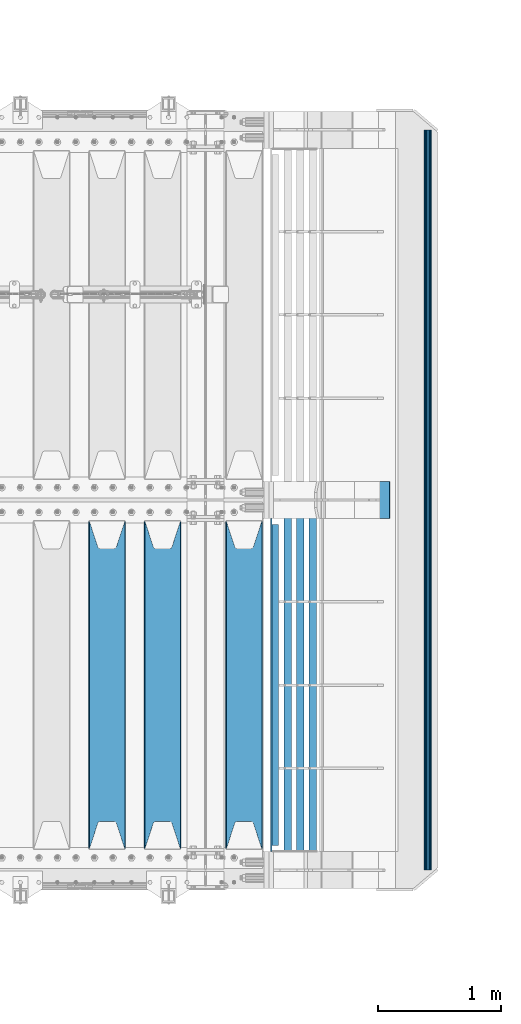
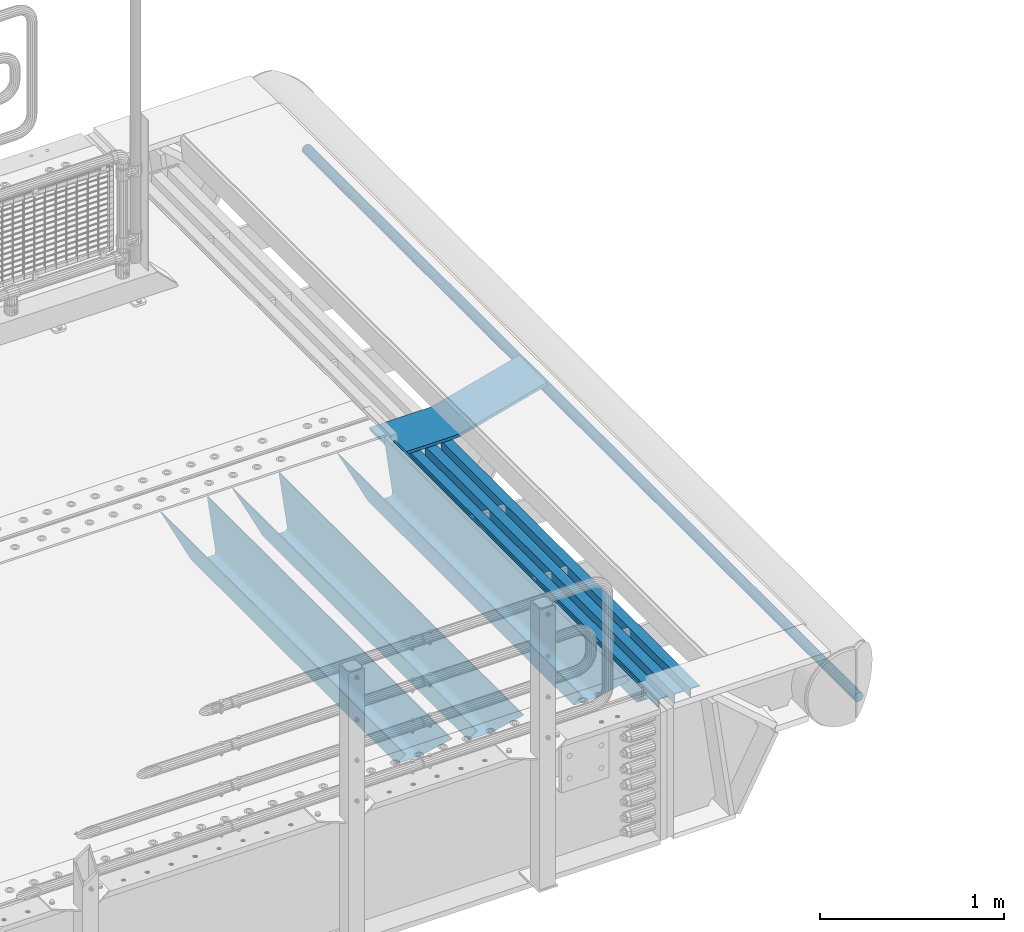
# One storey, part 131 of 242: 9 beams.
"""IFC2X3 building model written with IfcOpenShell, lengths in millimetres."""

import ifcopenshell
import ifcopenshell.guid

model = None  # the IFC model being written
_history = None  # IfcOwnerHistory: only IFC2X3 demands one
_inside = {}  # id of a spatial element -> (the spatial element, [elements in it])
_under = {}  # id of a project, library or spatial element -> (it, [spatial elements below it])
_declared = {}  # id of a project -> (the project, [libraries it declares])
_typed = {}  # id of a type object -> (the type object, [elements of that type])
_made_of = {}  # id of a material, layer set ... -> (it, [elements and type objects made of it])


def new_model(schema):
    """Start an empty IFC model of exactly this schema.

    Asked for "IFC4X3", IfcOpenShell would pick the latest addendum, in which some entities
    have other attributes; the version numbers below select the first issue.
    IFC2X3 requires an IfcOwnerHistory on every rooted entity: one is made here for all.
    """
    global model, _history
    if schema == "IFC4X3":
        model = ifcopenshell.file(schema_version=(4, 3, 0, 0))
    else:
        model = ifcopenshell.file(schema=schema)
    _inside.clear()
    _under.clear()
    _declared.clear()
    _typed.clear()
    _made_of.clear()
    _history = None
    if model.schema == "IFC2X3":
        org = make("IfcOrganization", Name="unknown")
        user = make(
            "IfcPersonAndOrganization",
            ThePerson=make("IfcPerson", FamilyName="unknown"),
            TheOrganization=org,
        )
        app = make(
            "IfcApplication",
            ApplicationDeveloper=org,
            Version="unknown",
            ApplicationFullName="unknown",
            ApplicationIdentifier="unknown",
        )
        _history = make(
            "IfcOwnerHistory",
            OwningUser=user,
            OwningApplication=app,
            ChangeAction="ADDED",
            CreationDate=0,
        )
    return model


def make(cls, **values):
    """One entity of the class cls with the attributes given. An attribute that is None is left unset."""
    return model.create_entity(
        cls, **{name: value for name, value in values.items() if value is not None}
    )


def rooted(cls, **values):
    """An entity with a GlobalId (a new one), such as an element, a storey or a relation."""
    return make(cls, GlobalId=ifcopenshell.guid.new(), OwnerHistory=_history, **values)


def si_unit(unit_type, name, prefix=None):
    """IfcSIUnit, for example si_unit("LENGTHUNIT", "METRE", prefix="MILLI")."""
    return make("IfcSIUnit", UnitType=unit_type, Prefix=prefix, Name=name)


def assignment(units):
    """IfcUnitAssignment: the units of a project."""
    return None if units is None else make("IfcUnitAssignment", Units=units)


def point(xyz):
    """IfcCartesianPoint."""
    return None if xyz is None else make("IfcCartesianPoint", Coordinates=xyz)


def direction(xyz):
    """IfcDirection."""
    return None if xyz is None else make("IfcDirection", DirectionRatios=xyz)


def frame(location, z_axis=None, x_axis=None):
    """IfcAxis2Placement3D, a coordinate frame: its origin and axes. An axis left out is left unset."""
    return make(
        "IfcAxis2Placement3D",
        Location=point(location),
        Axis=direction(z_axis),
        RefDirection=direction(x_axis),
    )


def origin_with_axes():
    """The frame at (0, 0, 0) with the z axis (0, 0, 1) and the x axis (1, 0, 0) written out."""
    return frame((0.0, 0.0, 0.0), z_axis=(0.0, 0.0, 1.0), x_axis=(1.0, 0.0, 0.0))


def place(relative_to, where):
    """IfcLocalPlacement: puts the frame where relative to a parent placement (None: the world)."""
    return make(
        "IfcLocalPlacement", PlacementRelTo=relative_to, RelativePlacement=where
    )


def context(
    kind, dimensions, precision=None, world=None, true_north=None, identifier=None
):
    """IfcGeometricRepresentationContext, for example the 3D "Model" context."""
    return make(
        "IfcGeometricRepresentationContext",
        ContextIdentifier=identifier,
        ContextType=kind,
        CoordinateSpaceDimension=dimensions,
        Precision=precision,
        WorldCoordinateSystem=world,
        TrueNorth=true_north,
    )


def subcontext(parent, identifier, kind, view, scale=None):
    """IfcGeometricRepresentationSubContext, for example "Body" below "Model"."""
    return make(
        "IfcGeometricRepresentationSubContext",
        ContextIdentifier=identifier,
        ContextType=kind,
        ParentContext=parent,
        TargetScale=scale,
        TargetView=view,
    )


def project(units=None, contexts=None):
    """IfcProject with its units and contexts."""
    return rooted(
        "IfcProject",
        Name="project",
        RepresentationContexts=contexts,
        UnitsInContext=assignment(units),
    )


def spatial(cls, under=None, at=None, **own):
    """A site, building, storey or space (cls), placed at a placement, below another one or the project."""
    s = rooted(cls, ObjectPlacement=at, **own)
    if under is not None:
        _under.setdefault(under.id(), (under, []))[1].append(s)
    return s


def faces_of(points, faces, orient=None, outer=None):
    """IfcFace entities. A face is a list of loops; a loop is a list of indices into points, from 0.

    orient and outer hold one flag for each loop. By default every Orientation is true, the
    first loop of a face is its IfcFaceOuterBound and the others are IfcFaceBound.
    """
    made = []
    for i, loops in enumerate(faces):
        bounds = []
        for j, loop in enumerate(loops):
            is_outer = j == 0 if outer is None else outer[i][j]
            bounds.append(
                make(
                    "IfcFaceOuterBound" if is_outer else "IfcFaceBound",
                    Bound=make("IfcPolyLoop", Polygon=[points[k] for k in loop]),
                    Orientation=True if orient is None else orient[i][j],
                )
            )
        made.append(make("IfcFace", Bounds=bounds))
    return made


def faceted_brep(points, faces, orient=None, outer=None, voids=None):
    """IfcFacetedBrep: a solid bounded by flat faces; with voids (closed shells), ...WithVoids."""
    shared = [point(p) for p in points]
    hull = make("IfcClosedShell", CfsFaces=faces_of(shared, faces, orient, outer))
    if voids is None:
        return make("IfcFacetedBrep", Outer=hull)
    return make(
        "IfcFacetedBrepWithVoids",
        Outer=hull,
        Voids=[
            make(cls, CfsFaces=faces_of(shared, fs, o, b)) for cls, fs, o, b in voids
        ],
    )


def shape(context_of_items, identifier, shape_type, items):
    """IfcShapeRepresentation: the items that make up one representation, for example the "Body"."""
    return make(
        "IfcShapeRepresentation",
        ContextOfItems=context_of_items,
        RepresentationIdentifier=identifier,
        RepresentationType=shape_type,
        Items=items,
    )


def material(Name=None, Category=None):
    """IfcMaterial."""
    return make("IfcMaterial", Name=Name, Category=Category)


def made_of(thing, what):
    """Note that an element or type object is made of a material, layer set ...; save() writes the relation."""
    if what is not None:
        _made_of.setdefault(what.id(), (what, []))[1].append(thing)
    return thing


def type_object(cls, material=None, **own):
    """A type object (cls), such as IfcWallType, which elements share."""
    return made_of(rooted(cls, **own), material)


def element(
    cls,
    number,
    at=None,
    inside=None,
    cuts=None,
    type_object=None,
    material=None,
    context=None,
    identifier="Body",
    shape_type=None,
    held_by="IfcProductDefinitionShape",
    body=None,
    shapes=None,
    **own,
):
    """One element of the class cls, such as IfcWall. Its Tag is "e" and its number.

    at: its placement. inside: the storey or other place that contains it. cuts: it is an
    opening in that element (IfcRelVoidsElement). A single representation is given by context,
    identifier, shape_type and body (its items); several are given by shapes. held_by: the class
    of the entity that holds the representations. save() writes the other relations.
    """
    e = rooted(cls, Tag="e%d" % number, ObjectPlacement=at, **own)
    if body is not None:
        shapes = [shape(context, identifier, shape_type, body)]
    if shapes is not None:
        e.Representation = make(held_by, Representations=shapes)
    if inside is not None:
        _inside.setdefault(inside.id(), (inside, []))[1].append(e)
    if cuts is not None:
        rooted(
            "IfcRelVoidsElement", RelatingBuildingElement=cuts, RelatedOpeningElement=e
        )
    if type_object is not None:
        _typed.setdefault(type_object.id(), (type_object, []))[1].append(e)
    return made_of(e, material)


def aggregate(whole, parts):
    """IfcRelAggregates: a whole, such as a stair, and the parts it consists of."""
    return rooted("IfcRelAggregates", RelatingObject=whole, RelatedObjects=parts)


def save(model, path):
    """Write the relations noted so far, then the file.

    IfcRelAggregates (storeys below a building ...), IfcRelContainedInSpatialStructure (elements
    in a storey), IfcRelDefinesByType, IfcRelAssociatesMaterial and IfcRelDeclares: one each for
    every whole, place, type object, material and project.
    """
    for whole, parts in _under.values():
        aggregate(whole, parts)
    for where, things in _inside.values():
        rooted(
            "IfcRelContainedInSpatialStructure",
            RelatedElements=things,
            RelatingStructure=where,
        )
    for kind, things in _typed.values():
        rooted("IfcRelDefinesByType", RelatedObjects=things, RelatingType=kind)
    for what, things in _made_of.values():
        rooted("IfcRelAssociatesMaterial", RelatedObjects=things, RelatingMaterial=what)
    for by, libraries in _declared.values():
        rooted("IfcRelDeclares", RelatingContext=by, RelatedDefinitions=libraries)
    model.write(path)


model = new_model("IFC2X3")

# Units and contexts
model_context = context("Model", 3, precision=1e-05, world=origin_with_axes())
body_context = subcontext(model_context, "Body", "Model", "MODEL_VIEW")
ifc_project = project(units=[si_unit("LENGTHUNIT", "METRE", prefix="MILLI"), si_unit("AREAUNIT", "SQUARE_METRE"), si_unit("VOLUMEUNIT", "CUBIC_METRE"), si_unit("MASSUNIT", "GRAM", prefix="KILO"), si_unit("TIMEUNIT", "SECOND"), si_unit("PLANEANGLEUNIT", "RADIAN"), si_unit("SOLIDANGLEUNIT", "STERADIAN"), si_unit("THERMODYNAMICTEMPERATUREUNIT", "DEGREE_CELSIUS"), si_unit("LUMINOUSINTENSITYUNIT", "LUMEN")], contexts=[model_context])

# Site, building, storey
site_placement = place(None, origin_with_axes())
site = spatial("IfcSite", under=ifc_project, at=site_placement, CompositionType="ELEMENT")
building_placement = place(site_placement, origin_with_axes())
building = spatial("IfcBuilding", under=site, at=building_placement, Name="Standard", CompositionType="ELEMENT")
storey_placement = place(building_placement, origin_with_axes())
storey = spatial("IfcBuildingStorey", under=building, at=storey_placement, Name="Undefined", CompositionType="ELEMENT", Elevation=0.0)

# Beams
ifc_material_1 = material(Name="STEEL/S355N")
beam_type_1 = type_object("IfcBeamType", PredefinedType="NOTDEFINED")
beam_1_placement = place(storey_placement, frame((-22220.0, -23825.0, -115.0), z_axis=(0.0, 0.0, 1.0), x_axis=(0.0, 1.0, 0.0)))
element("IfcBeam", 1, at=beam_1_placement, inside=storey, type_object=beam_type_1, material=ifc_material_1, context=body_context, shape_type="Brep", body=[
    faceted_brep([(0.0, 150.0, 115.0), (0.0, 143.689999999999, 115.0), (2650.00000000297, 143.689999999999, 115.0), (2650.00000000297, 150.0, 115.0), (2650.00000000297, 142.059565218402, 110.000000003099), (2650.00000000297, 148.369565218403, 110.000000003099), (2441.90079219209, -80.1103600731112, -98.0992078077845), (2437.7588105432, -77.5672621345584, -102.241189456673), (2434.06523489747, -74.4080125315522, -105.934765102404), (2430.91086095089, -70.710272125576, -109.089139048974), (2428.37322971128, -66.5649389910068, -111.626770288588), (2426.51472138055, -62.0739139532889, -113.485278619323), (2425.38102192092, -57.3475956567672, -114.618978078955), (2424.99999999987, -52.5021667386536, -115.0), (2424.99999999987, 52.5021667386536, -115.0), (2425.38102192092, 57.3475956567672, -114.618978078955), (2426.51472138055, 62.0739139532889, -113.485278619323), (2428.37322971128, 66.5649389910068, -111.626770288588), (2430.91086095089, 70.710272125576, -109.089139048974), (2434.06523489747, 74.4080125315522, -105.934765102404), (2437.7588105432, 77.5672621345584, -102.241189456673), (2441.90079219209, 80.1103600731112, -98.0992078077846), (2446.38936140511, 81.9747917625791, -93.6106385947584), (2448.2494850041, 76.2713538057251, -91.7505149957729), (2444.62967112262, 74.76777986261, -95.3703288772456), (2441.28936334126, 72.7168944282894, -98.710636658607), (2438.31067330438, 70.1691124903846, -101.689326695487), (2435.76682334747, 67.1870637758839, -104.233176652398), (2433.72034654133, 63.8440531834895, -106.279653458539), (2432.22154950042, 60.222258798236, -107.778450499454), (2431.30727574265, 56.4107117849089, -108.692724257221), (2430.99999999987, 52.5031078186876, -109.0), (2430.99999999987, -52.5031078186876, -109.0), (2431.30727574265, -56.4107117849089, -108.692724257221), (2432.22154950042, -60.222258798236, -107.778450499454), (2433.72034654133, -63.8440531834895, -106.279653458539), (2435.76682334747, -67.1870637758839, -104.233176652398), (2438.31067330438, -70.1691124903846, -101.689326695487), (2441.28936334126, -72.7168944282894, -98.7106366586071), (2444.62967112262, -74.76777986261, -95.3703288772457), (2448.2494850041, -76.2713538057251, -91.7505149957729), (2650.00000000297, -142.059565218402, 110.000000003099), (2650.00000000297, -148.369565218403, 110.000000003099), (2446.38936140511, -81.9747917625791, -93.6106385947584), (2650.00000000297, -143.689999999999, 115.0), (2650.00000000297, -150.0, 115.0), (0.0, -143.689999999999, 115.0), (0.0, -150.0, 115.0), (0.0, -148.369565218261, 110.000000002669), (203.610638597427, -81.9747917625791, -93.6106385947584), (208.099207810454, -80.1103600731112, -98.0992078077845), (212.241189459342, -77.5672621345584, -102.241189456673), (215.934765105074, -74.4080125315522, -105.934765102404), (219.089139051644, -70.710272125576, -109.089139048974), (221.626770291256, -66.5649389910068, -111.626770288588), (223.485278621993, -62.0739139532889, -113.485278619323), (224.618978081624, -57.3475956567672, -114.618978078955), (225.00000000267, -52.5021667386536, -115.0), (225.00000000267, 52.5021667386536, -115.0), (224.618978081624, 57.3475956567672, -114.618978078955), (223.485278621993, 62.0739139532889, -113.485278619323), (221.626770291256, 66.5649389910068, -111.626770288588), (219.089139051644, 70.710272125576, -109.089139048974), (215.934765105074, 74.4080125315522, -105.934765102404), (212.241189459342, 77.5672621345584, -102.241189456673), (208.099207810454, 80.1103600731112, -98.0992078077846), (203.610638597427, 81.9747917625791, -93.6106385947584), (0.0, 148.369565218261, 110.000000002669), (0.0, 142.05956521826, 110.000000002669), (201.750514998443, 76.2713538057251, -91.7505149957729), (205.370328879915, 74.76777986261, -95.3703288772456), (208.710636661275, 72.7168944282894, -98.710636658607), (211.689326698157, 70.1691124903846, -101.689326695487), (214.233176655067, 67.1870637758839, -104.233176652398), (216.279653461206, 63.8440531834895, -106.279653458539), (217.778450502123, 60.222258798236, -107.778450499454), (218.69272425989, 56.4107117849089, -108.692724257221), (219.00000000267, 52.5031078186876, -109.0), (219.00000000267, -52.5031078186876, -109.0), (218.69272425989, -56.4107117849089, -108.692724257221), (217.778450502123, -60.222258798236, -107.778450499454), (216.279653461206, -63.8440531834895, -106.279653458539), (214.233176655067, -67.1870637758839, -104.233176652398), (211.689326698157, -70.1691124903846, -101.689326695487), (208.710636661275, -72.7168944282894, -98.7106366586071), (205.370328879915, -74.76777986261, -95.3703288772457), (201.750514998443, -76.2713538057251, -91.7505149957729), (0.0, -142.05956521826, 110.000000002669)], [[[0, 1, 2, 3]], [[3, 2, 4, 5]], [[6, 7, 8, 9, 10, 11, 12, 13, 14, 15, 16, 17, 18, 19, 20, 21, 22, 5, 4, 23, 24, 25, 26, 27, 28, 29, 30, 31, 32, 33, 34, 35, 36, 37, 38, 39, 40, 41, 42, 43]], [[44, 45, 42, 41]], [[46, 47, 45, 44]], [[43, 42, 45, 47, 48, 49]], [[6, 43, 49, 50]], [[7, 6, 50, 51]], [[8, 7, 51, 52]], [[9, 8, 52, 53]], [[10, 9, 53, 54]], [[11, 10, 54, 55]], [[12, 11, 55, 56]], [[13, 12, 56, 57]], [[14, 13, 57, 58]], [[15, 14, 58, 59]], [[16, 15, 59, 60]], [[17, 16, 60, 61]], [[18, 17, 61, 62]], [[19, 18, 62, 63]], [[20, 19, 63, 64]], [[21, 20, 64, 65]], [[22, 21, 65, 66]], [[0, 3, 5, 22, 66, 67]], [[1, 0, 67, 68]], [[23, 4, 2, 1, 68, 69]], [[24, 23, 69, 70]], [[25, 24, 70, 71]], [[26, 25, 71, 72]], [[27, 26, 72, 73]], [[28, 27, 73, 74]], [[29, 28, 74, 75]], [[30, 29, 75, 76]], [[31, 30, 76, 77]], [[32, 31, 77, 78]], [[33, 32, 78, 79]], [[34, 33, 79, 80]], [[35, 34, 80, 81]], [[36, 35, 81, 82]], [[37, 36, 82, 83]], [[38, 37, 83, 84]], [[39, 38, 84, 85]], [[40, 39, 85, 86]], [[46, 44, 41, 40, 86, 87]], [[47, 46, 87, 48]], [[86, 85, 84, 83, 82, 81, 80, 79, 78, 77, 76, 75, 74, 73, 72, 71, 70, 69, 68, 67, 66, 65, 64, 63, 62, 61, 60, 59, 58, 57, 56, 55, 54, 53, 52, 51, 50, 49, 48, 87]]]),
])
beam_2_placement = place(storey_placement, frame((-22880.0, -23825.0, -115.0), z_axis=(0.0, 0.0, 1.0), x_axis=(0.0, 1.0, 0.0)))
element("IfcBeam", 2, at=beam_2_placement, inside=storey, type_object=beam_type_1, material=ifc_material_1, context=body_context, shape_type="Brep", body=[
    faceted_brep([(0.0, 150.0, 115.0), (0.0, 143.689999999999, 115.0), (2650.00000000297, 143.689999999999, 115.0), (2650.00000000297, 150.0, 115.0), (2650.00000000297, 142.059565218402, 110.000000003099), (2650.00000000297, 148.369565218403, 110.000000003099), (2441.90079219209, -80.1103600731112, -98.0992078077845), (2437.7588105432, -77.5672621345584, -102.241189456673), (2434.06523489747, -74.4080125315522, -105.934765102404), (2430.91086095089, -70.710272125576, -109.089139048974), (2428.37322971128, -66.5649389910068, -111.626770288588), (2426.51472138055, -62.0739139532889, -113.485278619323), (2425.38102192092, -57.3475956567672, -114.618978078955), (2424.99999999987, -52.5021667386536, -115.0), (2424.99999999987, 52.5021667386536, -115.0), (2425.38102192092, 57.3475956567672, -114.618978078955), (2426.51472138055, 62.0739139532889, -113.485278619323), (2428.37322971128, 66.5649389910068, -111.626770288588), (2430.91086095089, 70.710272125576, -109.089139048974), (2434.06523489747, 74.4080125315522, -105.934765102404), (2437.7588105432, 77.5672621345584, -102.241189456673), (2441.90079219209, 80.1103600731112, -98.0992078077846), (2446.38936140511, 81.9747917625791, -93.6106385947584), (2448.2494850041, 76.2713538057251, -91.7505149957729), (2444.62967112262, 74.76777986261, -95.3703288772456), (2441.28936334126, 72.7168944282894, -98.710636658607), (2438.31067330438, 70.1691124903846, -101.689326695487), (2435.76682334747, 67.1870637758839, -104.233176652398), (2433.72034654133, 63.8440531834895, -106.279653458539), (2432.22154950042, 60.222258798236, -107.778450499454), (2431.30727574265, 56.4107117849089, -108.692724257221), (2430.99999999987, 52.5031078186876, -109.0), (2430.99999999987, -52.5031078186876, -109.0), (2431.30727574265, -56.4107117849089, -108.692724257221), (2432.22154950042, -60.222258798236, -107.778450499454), (2433.72034654133, -63.8440531834895, -106.279653458539), (2435.76682334747, -67.1870637758839, -104.233176652398), (2438.31067330438, -70.1691124903846, -101.689326695487), (2441.28936334126, -72.7168944282894, -98.7106366586071), (2444.62967112262, -74.76777986261, -95.3703288772457), (2448.2494850041, -76.2713538057251, -91.7505149957729), (2650.00000000297, -142.059565218402, 110.000000003099), (2650.00000000297, -148.369565218403, 110.000000003099), (2446.38936140511, -81.9747917625791, -93.6106385947584), (2650.00000000297, -143.689999999999, 115.0), (2650.00000000297, -150.0, 115.0), (0.0, -143.689999999999, 115.0), (0.0, -150.0, 115.0), (0.0, -148.369565218261, 110.000000002669), (203.610638597427, -81.9747917625791, -93.6106385947584), (208.099207810454, -80.1103600731112, -98.0992078077845), (212.241189459342, -77.5672621345584, -102.241189456673), (215.934765105074, -74.4080125315522, -105.934765102404), (219.089139051644, -70.710272125576, -109.089139048974), (221.626770291256, -66.5649389910068, -111.626770288588), (223.485278621993, -62.0739139532889, -113.485278619323), (224.618978081624, -57.3475956567672, -114.618978078955), (225.00000000267, -52.5021667386536, -115.0), (225.00000000267, 52.5021667386536, -115.0), (224.618978081624, 57.3475956567672, -114.618978078955), (223.485278621993, 62.0739139532889, -113.485278619323), (221.626770291256, 66.5649389910068, -111.626770288588), (219.089139051644, 70.710272125576, -109.089139048974), (215.934765105074, 74.4080125315522, -105.934765102404), (212.241189459342, 77.5672621345584, -102.241189456673), (208.099207810454, 80.1103600731112, -98.0992078077846), (203.610638597427, 81.9747917625791, -93.6106385947584), (0.0, 148.369565218261, 110.000000002669), (0.0, 142.05956521826, 110.000000002669), (201.750514998443, 76.2713538057251, -91.7505149957729), (205.370328879915, 74.76777986261, -95.3703288772456), (208.710636661275, 72.7168944282894, -98.710636658607), (211.689326698157, 70.1691124903846, -101.689326695487), (214.233176655067, 67.1870637758839, -104.233176652398), (216.279653461206, 63.8440531834895, -106.279653458539), (217.778450502123, 60.222258798236, -107.778450499454), (218.69272425989, 56.4107117849089, -108.692724257221), (219.00000000267, 52.5031078186876, -109.0), (219.00000000267, -52.5031078186876, -109.0), (218.69272425989, -56.4107117849089, -108.692724257221), (217.778450502123, -60.222258798236, -107.778450499454), (216.279653461206, -63.8440531834895, -106.279653458539), (214.233176655067, -67.1870637758839, -104.233176652398), (211.689326698157, -70.1691124903846, -101.689326695487), (208.710636661275, -72.7168944282894, -98.7106366586071), (205.370328879915, -74.76777986261, -95.3703288772457), (201.750514998443, -76.2713538057251, -91.7505149957729), (0.0, -142.05956521826, 110.000000002669)], [[[0, 1, 2, 3]], [[3, 2, 4, 5]], [[6, 7, 8, 9, 10, 11, 12, 13, 14, 15, 16, 17, 18, 19, 20, 21, 22, 5, 4, 23, 24, 25, 26, 27, 28, 29, 30, 31, 32, 33, 34, 35, 36, 37, 38, 39, 40, 41, 42, 43]], [[44, 45, 42, 41]], [[46, 47, 45, 44]], [[43, 42, 45, 47, 48, 49]], [[6, 43, 49, 50]], [[7, 6, 50, 51]], [[8, 7, 51, 52]], [[9, 8, 52, 53]], [[10, 9, 53, 54]], [[11, 10, 54, 55]], [[12, 11, 55, 56]], [[13, 12, 56, 57]], [[14, 13, 57, 58]], [[15, 14, 58, 59]], [[16, 15, 59, 60]], [[17, 16, 60, 61]], [[18, 17, 61, 62]], [[19, 18, 62, 63]], [[20, 19, 63, 64]], [[21, 20, 64, 65]], [[22, 21, 65, 66]], [[0, 3, 5, 22, 66, 67]], [[1, 0, 67, 68]], [[23, 4, 2, 1, 68, 69]], [[24, 23, 69, 70]], [[25, 24, 70, 71]], [[26, 25, 71, 72]], [[27, 26, 72, 73]], [[28, 27, 73, 74]], [[29, 28, 74, 75]], [[30, 29, 75, 76]], [[31, 30, 76, 77]], [[32, 31, 77, 78]], [[33, 32, 78, 79]], [[34, 33, 79, 80]], [[35, 34, 80, 81]], [[36, 35, 81, 82]], [[37, 36, 82, 83]], [[38, 37, 83, 84]], [[39, 38, 84, 85]], [[40, 39, 85, 86]], [[46, 44, 41, 40, 86, 87]], [[47, 46, 87, 48]], [[86, 85, 84, 83, 82, 81, 80, 79, 78, 77, 76, 75, 74, 73, 72, 71, 70, 69, 68, 67, 66, 65, 64, 63, 62, 61, 60, 59, 58, 57, 56, 55, 54, 53, 52, 51, 50, 49, 48, 87]]]),
])
beam_3_placement = place(storey_placement, frame((-23330.0, -23825.0, -115.0), z_axis=(0.0, 0.0, 1.0), x_axis=(0.0, 1.0, 0.0)))
element("IfcBeam", 3, at=beam_3_placement, inside=storey, type_object=beam_type_1, material=ifc_material_1, context=body_context, shape_type="Brep", body=[
    faceted_brep([(0.0, 150.0, 115.0), (0.0, 143.689999999999, 115.0), (2650.00000000297, 143.689999999999, 115.0), (2650.00000000297, 150.0, 115.0), (2650.00000000297, 142.059565218402, 110.000000003099), (2650.00000000297, 148.369565218403, 110.000000003099), (2441.90079219209, -80.1103600731112, -98.0992078077845), (2437.7588105432, -77.5672621345584, -102.241189456673), (2434.06523489747, -74.4080125315522, -105.934765102404), (2430.91086095089, -70.710272125576, -109.089139048974), (2428.37322971128, -66.5649389910068, -111.626770288588), (2426.51472138055, -62.0739139532889, -113.485278619323), (2425.38102192092, -57.3475956567672, -114.618978078955), (2424.99999999987, -52.5021667386536, -115.0), (2424.99999999987, 52.5021667386536, -115.0), (2425.38102192092, 57.3475956567672, -114.618978078955), (2426.51472138055, 62.0739139532889, -113.485278619323), (2428.37322971128, 66.5649389910068, -111.626770288588), (2430.91086095089, 70.710272125576, -109.089139048974), (2434.06523489747, 74.4080125315522, -105.934765102404), (2437.7588105432, 77.5672621345584, -102.241189456673), (2441.90079219209, 80.1103600731112, -98.0992078077846), (2446.38936140511, 81.9747917625791, -93.6106385947584), (2448.2494850041, 76.2713538057251, -91.7505149957729), (2444.62967112262, 74.76777986261, -95.3703288772456), (2441.28936334126, 72.7168944282894, -98.710636658607), (2438.31067330438, 70.1691124903846, -101.689326695487), (2435.76682334747, 67.1870637758839, -104.233176652398), (2433.72034654133, 63.8440531834895, -106.279653458539), (2432.22154950042, 60.222258798236, -107.778450499454), (2431.30727574265, 56.4107117849089, -108.692724257221), (2430.99999999987, 52.5031078186876, -109.0), (2430.99999999987, -52.5031078186876, -109.0), (2431.30727574265, -56.4107117849089, -108.692724257221), (2432.22154950042, -60.222258798236, -107.778450499454), (2433.72034654133, -63.8440531834895, -106.279653458539), (2435.76682334747, -67.1870637758839, -104.233176652398), (2438.31067330438, -70.1691124903846, -101.689326695487), (2441.28936334126, -72.7168944282894, -98.7106366586071), (2444.62967112262, -74.76777986261, -95.3703288772457), (2448.2494850041, -76.2713538057251, -91.7505149957729), (2650.00000000297, -142.059565218402, 110.000000003099), (2650.00000000297, -148.369565218403, 110.000000003099), (2446.38936140511, -81.9747917625791, -93.6106385947584), (2650.00000000297, -143.689999999999, 115.0), (2650.00000000297, -150.0, 115.0), (0.0, -143.689999999999, 115.0), (0.0, -150.0, 115.0), (0.0, -148.369565218261, 110.000000002669), (203.610638597427, -81.9747917625791, -93.6106385947584), (208.099207810454, -80.1103600731112, -98.0992078077845), (212.241189459342, -77.5672621345584, -102.241189456673), (215.934765105074, -74.4080125315522, -105.934765102404), (219.089139051644, -70.710272125576, -109.089139048974), (221.626770291256, -66.5649389910068, -111.626770288588), (223.485278621993, -62.0739139532889, -113.485278619323), (224.618978081624, -57.3475956567672, -114.618978078955), (225.00000000267, -52.5021667386536, -115.0), (225.00000000267, 52.5021667386536, -115.0), (224.618978081624, 57.3475956567672, -114.618978078955), (223.485278621993, 62.0739139532889, -113.485278619323), (221.626770291256, 66.5649389910068, -111.626770288588), (219.089139051644, 70.710272125576, -109.089139048974), (215.934765105074, 74.4080125315522, -105.934765102404), (212.241189459342, 77.5672621345584, -102.241189456673), (208.099207810454, 80.1103600731112, -98.0992078077846), (203.610638597427, 81.9747917625791, -93.6106385947584), (0.0, 148.369565218261, 110.000000002669), (0.0, 142.05956521826, 110.000000002669), (201.750514998443, 76.2713538057251, -91.7505149957729), (205.370328879915, 74.76777986261, -95.3703288772456), (208.710636661275, 72.7168944282894, -98.710636658607), (211.689326698157, 70.1691124903846, -101.689326695487), (214.233176655067, 67.1870637758839, -104.233176652398), (216.279653461206, 63.8440531834895, -106.279653458539), (217.778450502123, 60.222258798236, -107.778450499454), (218.69272425989, 56.4107117849089, -108.692724257221), (219.00000000267, 52.5031078186876, -109.0), (219.00000000267, -52.5031078186876, -109.0), (218.69272425989, -56.4107117849089, -108.692724257221), (217.778450502123, -60.222258798236, -107.778450499454), (216.279653461206, -63.8440531834895, -106.279653458539), (214.233176655067, -67.1870637758839, -104.233176652398), (211.689326698157, -70.1691124903846, -101.689326695487), (208.710636661275, -72.7168944282894, -98.7106366586071), (205.370328879915, -74.76777986261, -95.3703288772457), (201.750514998443, -76.2713538057251, -91.7505149957729), (0.0, -142.05956521826, 110.000000002669)], [[[0, 1, 2, 3]], [[3, 2, 4, 5]], [[6, 7, 8, 9, 10, 11, 12, 13, 14, 15, 16, 17, 18, 19, 20, 21, 22, 5, 4, 23, 24, 25, 26, 27, 28, 29, 30, 31, 32, 33, 34, 35, 36, 37, 38, 39, 40, 41, 42, 43]], [[44, 45, 42, 41]], [[46, 47, 45, 44]], [[43, 42, 45, 47, 48, 49]], [[6, 43, 49, 50]], [[7, 6, 50, 51]], [[8, 7, 51, 52]], [[9, 8, 52, 53]], [[10, 9, 53, 54]], [[11, 10, 54, 55]], [[12, 11, 55, 56]], [[13, 12, 56, 57]], [[14, 13, 57, 58]], [[15, 14, 58, 59]], [[16, 15, 59, 60]], [[17, 16, 60, 61]], [[18, 17, 61, 62]], [[19, 18, 62, 63]], [[20, 19, 63, 64]], [[21, 20, 64, 65]], [[22, 21, 65, 66]], [[0, 3, 5, 22, 66, 67]], [[1, 0, 67, 68]], [[23, 4, 2, 1, 68, 69]], [[24, 23, 69, 70]], [[25, 24, 70, 71]], [[26, 25, 71, 72]], [[27, 26, 72, 73]], [[28, 27, 73, 74]], [[29, 28, 74, 75]], [[30, 29, 75, 76]], [[31, 30, 76, 77]], [[32, 31, 77, 78]], [[33, 32, 78, 79]], [[34, 33, 79, 80]], [[35, 34, 80, 81]], [[36, 35, 81, 82]], [[37, 36, 82, 83]], [[38, 37, 83, 84]], [[39, 38, 84, 85]], [[40, 39, 85, 86]], [[46, 44, 41, 40, 86, 87]], [[47, 46, 87, 48]], [[86, 85, 84, 83, 82, 81, 80, 79, 78, 77, 76, 75, 74, 73, 72, 71, 70, 69, 68, 67, 66, 65, 64, 63, 62, 61, 60, 59, 58, 57, 56, 55, 54, 53, 52, 51, 50, 49, 48, 87]]]),
])
ifc_material_2 = material(Name="STEEL/S355J2")
beam_type_2 = type_object("IfcBeamType", PredefinedType="NOTDEFINED")
beam_4_placement = place(storey_placement, frame((-21972.4974739935, -23850.0, -124.999999999985), z_axis=(0.0, 0.0, 1.0), x_axis=(0.0, 1.0, 0.0)))
element("IfcBeam", 4, at=beam_4_placement, inside=storey, type_object=beam_type_2, material=ifc_material_2, context=body_context, shape_type="Brep", body=[
    faceted_brep([(2700.0, 22.5, -15.0), (2684.54915028125, 22.5000000000036, -17.4471741852423), (2684.54915028125, 32.5000000000036, -17.4471741852423), (2700.0, 32.5, -15.0), (2670.61073738538, 22.5000000000036, -24.5491502812526), (2670.61073738538, 32.5000000000036, -24.5491502812526), (2659.54915028125, 22.5000000000036, -35.6107373853764), (2659.54915028125, 32.5000000000036, -35.6107373853764), (2652.44717418524, 22.5000000000036, -49.5491502812526), (2652.44717418524, 32.5000000000036, -49.5491502812526), (2651.58384440325, -32.5, -55.0), (2650.0, -32.5, -65.0), (2650.0, 32.5, -65.0), (2651.58384440325, 22.5, -55.0), (0.0, 32.5, 65.0), (0.0, 22.5, 65.0), (2700.0, 22.5, 65.0), (2700.0, 32.5, 65.0), (0.0, 32.5, -15.0), (0.0, 22.5, -15.0), (15.4508497187489, 32.5, -17.4471741852423), (15.4508497187489, 22.5, -17.4471741852423), (29.3892626146226, 32.5, -24.5491502812526), (29.3892626146226, 22.5, -24.5491502812526), (40.4508497187489, 32.5, -35.6107373853764), (40.4508497187489, 22.5, -35.6107373853764), (47.5528258147569, 32.5, -49.5491502812526), (47.5528258147569, 22.5, -49.5491502812526), (50.0, -32.5, -65.0), (48.4161555967548, -32.5, -55.0), (48.4161555967548, 22.5, -55.0), (50.0, 32.5, -65.0)], [[[0, 1, 2, 3]], [[4, 5, 2, 1]], [[6, 7, 5, 4]], [[8, 9, 7, 6]], [[10, 11, 12, 9, 8, 13]], [[14, 15, 16, 17]], [[15, 14, 18, 19]], [[19, 18, 20, 21]], [[21, 20, 22, 23]], [[23, 22, 24, 25]], [[25, 24, 26, 27]], [[28, 29, 30, 27, 26, 31]], [[30, 29, 10, 13]], [[16, 15, 19, 21, 23, 25, 27, 30, 13, 8, 6, 4, 1, 0]], [[17, 16, 0, 3]], [[5, 7, 9, 12, 31, 26, 24, 22, 20, 18, 14, 17, 3, 2]], [[28, 31, 12, 11]], [[29, 28, 11, 10]]]),
])
beam_type_3 = type_object("IfcBeamType", PredefinedType="NOTDEFINED")
for number, where, z_axis, x_axis in (
    (5, (-21664.9975852833, -21130.0000023409, -210.000211453654), (0.0, 0.0, -1.0), (0.0, -1.0, 0.0)),
    (6, (-21764.9975852833, -21130.0000023409, -210.000211453654), (0.0, 0.0, -1.0), (0.0, -1.0, 0.0)),
    (7, (-21864.997585284, -21130.0000023409, -210.000211453713), (0.0, 0.0, -1.0), (0.0, -1.0, 0.0)),
):
    element("IfcBeam", number, at=place(storey_placement, frame(where, z_axis=z_axis, x_axis=x_axis)), inside=storey, type_object=beam_type_3, material=ifc_material_2, context=body_context, shape_type="Brep", body=[
        faceted_brep([(3.63797880709171e-12, 30.0, -30.0), (0.0, 30.0, 30.0000000000001), (2710.00000000001, 30.0, 30.0000000000001), (2710.00000000001, 30.0, -30.0), (0.0, 24.0, 30.0), (2710.00000000001, 24.0, 30.0), (0.0, 24.0, -24.0), (2710.00000000001, 24.0, -24.0), (3.63797880709171e-12, -30.0, -24.0), (2710.00000000001, -30.0, -24.0), (3.63797880709171e-12, -30.0, -30.0), (2710.00000000001, -30.0, -30.0)], [[[0, 1, 2, 3]], [[1, 4, 5, 2]], [[4, 6, 7, 5]], [[6, 8, 9, 7]], [[8, 10, 11, 9]], [[10, 0, 3, 11]], [[5, 7, 9, 11, 3, 2]], [[10, 8, 6, 4, 1, 0]]]),
    ])
beam_type_4 = type_object("IfcBeamType", PredefinedType="NOTDEFINED")
beam_5_placement = place(storey_placement, frame((-21980.0011701094, -21000.0, -169.999999999995), z_axis=(0.0, -1.0, 0.0), x_axis=(1.0, 0.0, 0.0)))
element("IfcBeam", 8, at=beam_5_placement, inside=storey, type_object=beam_type_4, material=ifc_material_1, context=body_context, shape_type="Brep", body=[
    faceted_brep([(0.0, 10.0, -150.0), (0.0, 10.0, 150.0), (356.495387467741, 10.0, 150.0), (356.495387467749, 9.99999999999858, -150.0), (0.0, -10.0, 150.0), (0.0, -10.0, -150.0), (356.495387467741, -10.0, -150.0), (356.495387467741, -10.0, 150.0), (382.770279632416, 11.7334369044538, 150.0), (382.770279632416, 11.7334369044538, -150.0), (385.397768848896, -8.09321940509972, -150.0), (385.397768848896, -8.09321940509972, 150.0), (413.799145684919, -2.40593045895696, -150.0), (413.799145684919, -2.40593045895696, 150.0), (408.589713119687, 16.9036995827633, 150.0), (408.589713119891, 16.9036995827009, -150.0), (939.000000000015, 160.0, 150.0), (939.000000000015, 160.0, -150.0), (944.209432565229, 140.69036995827, 150.0), (944.209432565229, 140.69036995827, -150.0)], [[[0, 1, 2, 3]], [[4, 5, 6, 7]], [[5, 4, 1, 0]], [[3, 2, 8, 9]], [[7, 6, 10, 11]], [[10, 12, 13, 11]], [[8, 14, 15, 9]], [[15, 14, 16, 17]], [[14, 8, 2, 1, 4, 7, 11, 13, 18, 16]], [[13, 12, 19, 18]], [[12, 10, 6, 5, 0, 3, 9, 15, 17, 19]], [[18, 19, 17, 16]]]),
])
beam_type_5 = type_object("IfcBeamType", Name="D60", PredefinedType="NOTDEFINED")
beam_6_placement = place(storey_placement, frame((-20730.2474739935, -24000.0, -478.0), z_axis=(0.0, 0.0, 1.0), x_axis=(0.0, 1.0, 0.0)))
element("IfcBeam", 9, at=beam_6_placement, inside=storey, type_object=beam_type_5, material=ifc_material_1, ObjectType="D60", context=body_context, shape_type="Brep", body=[
    faceted_brep([(0.0, -30.0, 0.0), (0.0, -27.7163859753418, -11.4805029709527), (6000.00000000114, -27.7163859753418, -11.4805029709527), (6000.00000000114, -30.0, 0.0), (0.0, -21.2132034356, -21.2132034355964), (6000.00000000114, -21.2132034356, -21.2132034355964), (0.0, -11.4805029709532, -27.7163859753386), (6000.00000000114, -11.4805029709532, -27.7163859753386), (0.0, -3.63797880709171e-12, -30.0), (6000.00000000114, -3.63797880709171e-12, -30.0), (0.0, 11.4805029709496, -27.7163859753386), (6000.00000000114, 11.4805029709496, -27.7163859753386), (0.0, 21.2132034355927, -21.2132034355964), (6000.00000000114, 21.2132034355927, -21.2132034355964), (0.0, 27.7163859753382, -11.4805029709527), (6000.00000000114, 27.7163859753382, -11.4805029709527), (0.0, 29.9999999999964, 0.0), (6000.00000000114, 29.9999999999964, 0.0), (0.0, 27.7163859753382, 11.4805029709527), (6000.00000000114, 27.7163859753382, 11.4805029709527), (0.0, 21.2132034355927, 21.2132034355964), (6000.00000000114, 21.2132034355927, 21.2132034355964), (0.0, 11.4805029709496, 27.7163859753386), (6000.00000000114, 11.4805029709496, 27.7163859753386), (0.0, -3.63797880709171e-12, 30.0), (6000.00000000114, -3.63797880709171e-12, 30.0), (0.0, -11.4805029709532, 27.7163859753386), (6000.00000000114, -11.4805029709532, 27.7163859753386), (0.0, -21.2132034356, 21.2132034355964), (6000.00000000114, -21.2132034356, 21.2132034355964), (0.0, -27.7163859753418, 11.4805029709527), (6000.00000000114, -27.7163859753418, 11.4805029709527)], [[[0, 1, 2, 3]], [[1, 4, 5, 2]], [[4, 6, 7, 5]], [[6, 8, 9, 7]], [[8, 10, 11, 9]], [[10, 12, 13, 11]], [[12, 14, 15, 13]], [[14, 16, 17, 15]], [[16, 18, 19, 17]], [[18, 20, 21, 19]], [[20, 22, 23, 21]], [[22, 24, 25, 23]], [[24, 26, 27, 25]], [[26, 28, 29, 27]], [[28, 30, 31, 29]], [[30, 0, 3, 31]], [[5, 7, 9, 11, 13, 15, 17, 19, 21, 23, 25, 27, 29, 31, 3, 2]], [[30, 28, 26, 24, 22, 20, 18, 16, 14, 12, 10, 8, 6, 4, 1, 0]]]),
])

save(model, "model.ifc")
